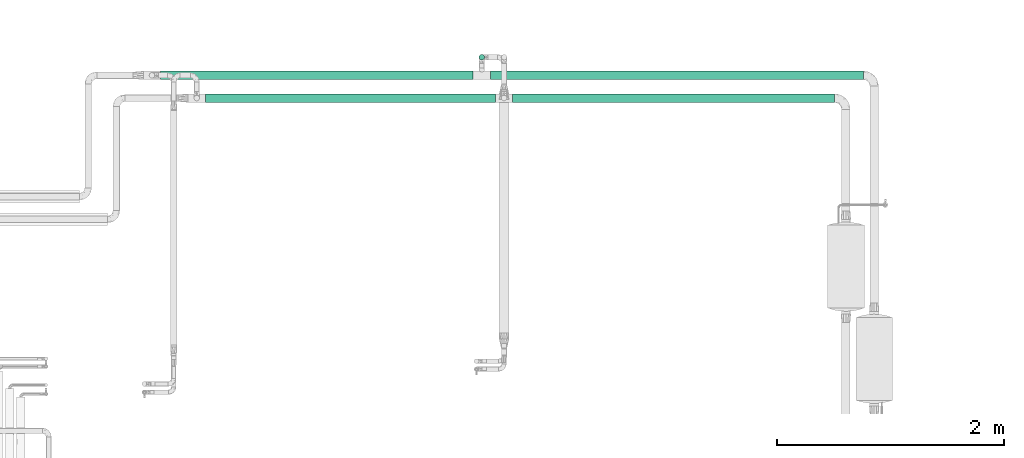
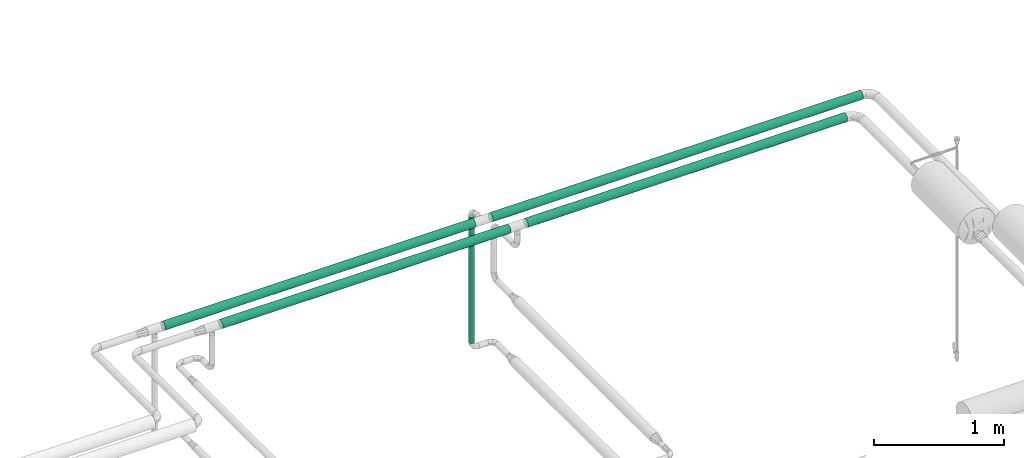
# One storey, part 529 of 827: 5 flow segments.
"""IFC2X3 building model written with IfcOpenShell, lengths in millimetres."""

import ifcopenshell
import ifcopenshell.guid

model = None  # the IFC model being written
_history = None  # IfcOwnerHistory: only IFC2X3 demands one
_inside = {}  # id of a spatial element -> (the spatial element, [elements in it])
_under = {}  # id of a project, library or spatial element -> (it, [spatial elements below it])
_declared = {}  # id of a project -> (the project, [libraries it declares])
_typed = {}  # id of a type object -> (the type object, [elements of that type])
_made_of = {}  # id of a material, layer set ... -> (it, [elements and type objects made of it])


def new_model(schema):
    """Start an empty IFC model of exactly this schema.

    Asked for "IFC4X3", IfcOpenShell would pick the latest addendum, in which some entities
    have other attributes; the version numbers below select the first issue.
    IFC2X3 requires an IfcOwnerHistory on every rooted entity: one is made here for all.
    """
    global model, _history
    if schema == "IFC4X3":
        model = ifcopenshell.file(schema_version=(4, 3, 0, 0))
    else:
        model = ifcopenshell.file(schema=schema)
    _inside.clear()
    _under.clear()
    _declared.clear()
    _typed.clear()
    _made_of.clear()
    _history = None
    if model.schema == "IFC2X3":
        org = make("IfcOrganization", Name="unknown")
        user = make(
            "IfcPersonAndOrganization",
            ThePerson=make("IfcPerson", FamilyName="unknown"),
            TheOrganization=org,
        )
        app = make(
            "IfcApplication",
            ApplicationDeveloper=org,
            Version="unknown",
            ApplicationFullName="unknown",
            ApplicationIdentifier="unknown",
        )
        _history = make(
            "IfcOwnerHistory",
            OwningUser=user,
            OwningApplication=app,
            ChangeAction="ADDED",
            CreationDate=0,
        )
    return model


def make(cls, **values):
    """One entity of the class cls with the attributes given. An attribute that is None is left unset."""
    return model.create_entity(
        cls, **{name: value for name, value in values.items() if value is not None}
    )


def entity(cls, *values):
    """Any entity or typed value of the class cls, its attributes in the order of the schema. None: left unset."""
    e = model.create_entity(cls)
    for i, value in enumerate(values):
        if value is not None:
            e[i] = value
    return e


def rooted(cls, **values):
    """An entity with a GlobalId (a new one), such as an element, a storey or a relation."""
    return make(cls, GlobalId=ifcopenshell.guid.new(), OwnerHistory=_history, **values)


def si_unit(unit_type, name, prefix=None):
    """IfcSIUnit, for example si_unit("LENGTHUNIT", "METRE", prefix="MILLI")."""
    return make("IfcSIUnit", UnitType=unit_type, Prefix=prefix, Name=name)


def converted_unit(unit_type, name, factor, base, dimensions=None, offset=None):
    """IfcConversionBasedUnit, such as the inch: factor (a typed value) times the base unit."""
    return make(
        "IfcConversionBasedUnit"
        if offset is None
        else "IfcConversionBasedUnitWithOffset",
        ConversionOffset=offset,
        Dimensions=None
        if dimensions is None
        else entity("IfcDimensionalExponents", *dimensions),
        UnitType=unit_type,
        Name=name,
        ConversionFactor=make(
            "IfcMeasureWithUnit", ValueComponent=factor, UnitComponent=base
        ),
    )


def derived_unit(unit_type, elements):
    """IfcDerivedUnit: a product of units, each with its exponent."""
    return make(
        "IfcDerivedUnit",
        Elements=[
            make("IfcDerivedUnitElement", Unit=unit, Exponent=power)
            for unit, power in elements
        ],
        UnitType=unit_type,
    )


def assignment(units):
    """IfcUnitAssignment: the units of a project."""
    return None if units is None else make("IfcUnitAssignment", Units=units)


def point(xyz):
    """IfcCartesianPoint."""
    return None if xyz is None else make("IfcCartesianPoint", Coordinates=xyz)


def direction(xyz):
    """IfcDirection."""
    return None if xyz is None else make("IfcDirection", DirectionRatios=xyz)


def frame(location, z_axis=None, x_axis=None):
    """IfcAxis2Placement3D, a coordinate frame: its origin and axes. An axis left out is left unset."""
    return make(
        "IfcAxis2Placement3D",
        Location=point(location),
        Axis=direction(z_axis),
        RefDirection=direction(x_axis),
    )


def frame_2d(location, x_axis=None):
    """IfcAxis2Placement2D, a coordinate frame in the plane: its origin and x axis."""
    return make(
        "IfcAxis2Placement2D", Location=point(location), RefDirection=direction(x_axis)
    )


def origin():
    """The frame at (0, 0, 0) with its axes left unset."""
    return frame((0.0, 0.0, 0.0))


def origin_2d_with_axis():
    """The frame at (0, 0) in the plane with the x axis (1, 0) written out."""
    return frame_2d((0.0, 0.0), x_axis=(1.0, 0.0))


def place(relative_to, where):
    """IfcLocalPlacement: puts the frame where relative to a parent placement (None: the world)."""
    return make(
        "IfcLocalPlacement", PlacementRelTo=relative_to, RelativePlacement=where
    )


def context(
    kind, dimensions, precision=None, world=None, true_north=None, identifier=None
):
    """IfcGeometricRepresentationContext, for example the 3D "Model" context."""
    return make(
        "IfcGeometricRepresentationContext",
        ContextIdentifier=identifier,
        ContextType=kind,
        CoordinateSpaceDimension=dimensions,
        Precision=precision,
        WorldCoordinateSystem=world,
        TrueNorth=true_north,
    )


def subcontext(parent, identifier, kind, view, scale=None):
    """IfcGeometricRepresentationSubContext, for example "Body" below "Model"."""
    return make(
        "IfcGeometricRepresentationSubContext",
        ContextIdentifier=identifier,
        ContextType=kind,
        ParentContext=parent,
        TargetScale=scale,
        TargetView=view,
    )


def project(units=None, contexts=None):
    """IfcProject with its units and contexts."""
    return rooted(
        "IfcProject",
        Name="project",
        RepresentationContexts=contexts,
        UnitsInContext=assignment(units),
    )


def spatial(cls, under=None, at=None, **own):
    """A site, building, storey or space (cls), placed at a placement, below another one or the project."""
    s = rooted(cls, ObjectPlacement=at, **own)
    if under is not None:
        _under.setdefault(under.id(), (under, []))[1].append(s)
    return s


def profile(cls, at=None, kind="AREA", **sizes):
    """A parametric profile (cls). Its sizes go by their IFC names, for example OverallWidth=200.0."""
    return make(cls, ProfileType=kind, Position=at, **sizes)


def circle(**sizes):
    """IfcCircleProfileDef."""
    return profile("IfcCircleProfileDef", **sizes)


def extrude(swept, where, along, depth):
    """IfcExtrudedAreaSolid: the profile swept, set in the frame where, extruded along a direction by depth."""
    return make(
        "IfcExtrudedAreaSolid",
        SweptArea=swept,
        Position=where,
        ExtrudedDirection=direction(along),
        Depth=depth,
    )


def shape(context_of_items, identifier, shape_type, items):
    """IfcShapeRepresentation: the items that make up one representation, for example the "Body"."""
    return make(
        "IfcShapeRepresentation",
        ContextOfItems=context_of_items,
        RepresentationIdentifier=identifier,
        RepresentationType=shape_type,
        Items=items,
    )


def made_of(thing, what):
    """Note that an element or type object is made of a material, layer set ...; save() writes the relation."""
    if what is not None:
        _made_of.setdefault(what.id(), (what, []))[1].append(thing)
    return thing


def type_object(cls, material=None, **own):
    """A type object (cls), such as IfcWallType, which elements share."""
    return made_of(rooted(cls, **own), material)


def element(
    cls,
    number,
    at=None,
    inside=None,
    cuts=None,
    type_object=None,
    material=None,
    context=None,
    identifier="Body",
    shape_type=None,
    held_by="IfcProductDefinitionShape",
    body=None,
    shapes=None,
    **own,
):
    """One element of the class cls, such as IfcWall. Its Tag is "e" and its number.

    at: its placement. inside: the storey or other place that contains it. cuts: it is an
    opening in that element (IfcRelVoidsElement). A single representation is given by context,
    identifier, shape_type and body (its items); several are given by shapes. held_by: the class
    of the entity that holds the representations. save() writes the other relations.
    """
    e = rooted(cls, Tag="e%d" % number, ObjectPlacement=at, **own)
    if body is not None:
        shapes = [shape(context, identifier, shape_type, body)]
    if shapes is not None:
        e.Representation = make(held_by, Representations=shapes)
    if inside is not None:
        _inside.setdefault(inside.id(), (inside, []))[1].append(e)
    if cuts is not None:
        rooted(
            "IfcRelVoidsElement", RelatingBuildingElement=cuts, RelatedOpeningElement=e
        )
    if type_object is not None:
        _typed.setdefault(type_object.id(), (type_object, []))[1].append(e)
    return made_of(e, material)


def aggregate(whole, parts):
    """IfcRelAggregates: a whole, such as a stair, and the parts it consists of."""
    return rooted("IfcRelAggregates", RelatingObject=whole, RelatedObjects=parts)


def save(model, path):
    """Write the relations noted so far, then the file.

    IfcRelAggregates (storeys below a building ...), IfcRelContainedInSpatialStructure (elements
    in a storey), IfcRelDefinesByType, IfcRelAssociatesMaterial and IfcRelDeclares: one each for
    every whole, place, type object, material and project.
    """
    for whole, parts in _under.values():
        aggregate(whole, parts)
    for where, things in _inside.values():
        rooted(
            "IfcRelContainedInSpatialStructure",
            RelatedElements=things,
            RelatingStructure=where,
        )
    for kind, things in _typed.values():
        rooted("IfcRelDefinesByType", RelatedObjects=things, RelatingType=kind)
    for what, things in _made_of.values():
        rooted("IfcRelAssociatesMaterial", RelatedObjects=things, RelatingMaterial=what)
    for by, libraries in _declared.values():
        rooted("IfcRelDeclares", RelatingContext=by, RelatedDefinitions=libraries)
    model.write(path)


model = new_model("IFC2X3")

# Units and contexts
model_context = context("Model", 3, precision=0.01, world=origin(), true_north=direction((6.12303176911189e-17, 1.0)))
body_context = subcontext(model_context, "Body", "Model", "MODEL_VIEW")
ifc_project = project(units=[si_unit("LENGTHUNIT", "METRE", prefix="MILLI"), si_unit("AREAUNIT", "SQUARE_METRE"), si_unit("VOLUMEUNIT", "CUBIC_METRE"), converted_unit("PLANEANGLEUNIT", "DEGREE", entity("IfcRatioMeasure", 0.0174532925199433), si_unit("PLANEANGLEUNIT", "RADIAN"), dimensions=[0, 0, 0, 0, 0, 0, 0]), si_unit("MASSUNIT", "GRAM", prefix="KILO"), derived_unit("MASSDENSITYUNIT", [(si_unit("MASSUNIT", "GRAM", prefix="KILO"), 1), (si_unit("LENGTHUNIT", "METRE"), -3)]), derived_unit("MOMENTOFINERTIAUNIT", [(si_unit("LENGTHUNIT", "METRE"), 4)]), si_unit("TIMEUNIT", "SECOND"), si_unit("FREQUENCYUNIT", "HERTZ"), si_unit("THERMODYNAMICTEMPERATUREUNIT", "DEGREE_CELSIUS"), derived_unit("THERMALTRANSMITTANCEUNIT", [(si_unit("MASSUNIT", "GRAM", prefix="KILO"), 1), (si_unit("THERMODYNAMICTEMPERATUREUNIT", "KELVIN"), -1), (si_unit("TIMEUNIT", "SECOND"), -3)]), derived_unit("VOLUMETRICFLOWRATEUNIT", [(si_unit("LENGTHUNIT", "METRE"), 3), (si_unit("TIMEUNIT", "SECOND"), -1)]), derived_unit("MASSFLOWRATEUNIT", [(si_unit("MASSUNIT", "GRAM", prefix="KILO"), 1), (si_unit("TIMEUNIT", "SECOND"), -1)]), derived_unit("ROTATIONALFREQUENCYUNIT", [(si_unit("TIMEUNIT", "SECOND"), -1)]), si_unit("ELECTRICCURRENTUNIT", "AMPERE"), si_unit("ELECTRICVOLTAGEUNIT", "VOLT"), si_unit("POWERUNIT", "WATT"), si_unit("FORCEUNIT", "NEWTON", prefix="KILO"), si_unit("ILLUMINANCEUNIT", "LUX"), si_unit("LUMINOUSFLUXUNIT", "LUMEN"), si_unit("LUMINOUSINTENSITYUNIT", "CANDELA"), derived_unit("USERDEFINED", [(si_unit("MASSUNIT", "GRAM", prefix="KILO"), -1), (si_unit("LENGTHUNIT", "METRE"), -2), (si_unit("TIMEUNIT", "SECOND"), 3), (si_unit("LUMINOUSFLUXUNIT", "LUMEN"), 1)]), derived_unit("LINEARVELOCITYUNIT", [(si_unit("LENGTHUNIT", "METRE"), 1), (si_unit("TIMEUNIT", "SECOND"), -1)]), si_unit("PRESSUREUNIT", "PASCAL"), derived_unit("USERDEFINED", [(si_unit("LENGTHUNIT", "METRE"), -2), (si_unit("MASSUNIT", "GRAM", prefix="KILO"), 1), (si_unit("TIMEUNIT", "SECOND"), -2)]), derived_unit("LINEARFORCEUNIT", [(si_unit("MASSUNIT", "GRAM", prefix="KILO"), 1), (si_unit("LENGTHUNIT", "METRE"), 1), (si_unit("TIMEUNIT", "SECOND"), -2), (si_unit("LENGTHUNIT", "METRE"), -1)]), derived_unit("PLANARFORCEUNIT", [(si_unit("MASSUNIT", "GRAM", prefix="KILO"), 1), (si_unit("LENGTHUNIT", "METRE"), 1), (si_unit("TIMEUNIT", "SECOND"), -2), (si_unit("LENGTHUNIT", "METRE"), -2)])], contexts=[model_context])

# Site, building, storey
site_placement = place(None, origin())
site = spatial("IfcSite", under=ifc_project, at=site_placement, CompositionType="ELEMENT")
building_placement = place(site_placement, origin())
building = spatial("IfcBuilding", under=site, at=building_placement, CompositionType="ELEMENT")
storey_placement = place(building_placement, frame((0.0, 0.0, 28200.0)))
storey = spatial("IfcBuildingStorey", under=building, at=storey_placement, Name="08", CompositionType="ELEMENT", Elevation=28200.0)

# Flow segments
pipe_segment_type_1 = type_object("IfcPipeSegmentType", PredefinedType="NOTDEFINED")
flow_segment_1_placement = place(storey_placement, frame((23012.46, 18840.4, 2960.4)))
element("IfcFlowSegment", 1, at=flow_segment_1_placement, inside=storey, type_object=pipe_segment_type_1, context=body_context, shape_type="SweptSolid", body=[
    extrude(circle(Radius=38.0, at=origin_2d_with_axis()), frame((0.0, 39.6, 39.6), z_axis=(1.0, 0.0, 0.0), x_axis=(0.0, -1.0, 0.0)), (0.0, 0.0, 1.0), 2831.71587502247),
])
flow_segment_2_placement = place(storey_placement, frame((22816.03, 19040.4, 2960.4)))
element("IfcFlowSegment", 2, at=flow_segment_2_placement, inside=storey, type_object=pipe_segment_type_1, context=body_context, shape_type="SweptSolid", body=[
    extrude(circle(Radius=38.0, at=origin_2d_with_axis()), frame((0.0, 39.6, 39.6), z_axis=(1.0, 0.0, 0.0), x_axis=(0.0, -1.0, 0.0)), (0.0, 0.0, 1.0), 3282.87594554333),
])
flow_segment_3_placement = place(storey_placement, frame((20307.46, 18840.4, 2960.4)))
element("IfcFlowSegment", 3, at=flow_segment_3_placement, inside=storey, type_object=pipe_segment_type_1, context=body_context, shape_type="SweptSolid", body=[
    extrude(circle(Radius=38.0, at=origin_2d_with_axis()), frame((0.0, 39.6, 39.6), z_axis=(1.0, 0.0, 0.0), x_axis=(0.0, -1.0, 0.0)), (0.0, 0.0, 1.0), 2553.0),
])
flow_segment_4_placement = place(storey_placement, frame((19913.21, 19040.4, 2960.4)))
element("IfcFlowSegment", 4, at=flow_segment_4_placement, inside=storey, type_object=pipe_segment_type_1, context=body_context, shape_type="SweptSolid", body=[
    extrude(circle(Radius=38.0, at=origin_2d_with_axis()), frame((0.0, 39.6, 39.6), z_axis=(1.0, 0.0, 0.0), x_axis=(0.0, -1.0, 0.0)), (0.0, 0.0, 1.0), 2750.82042068439),
])
pipe_segment_type_2 = type_object("IfcPipeSegmentType", PredefinedType="NOTDEFINED")
flow_segment_5_placement = place(storey_placement, frame((22714.44, 19214.7, 1764.06)))
element("IfcFlowSegment", 5, at=flow_segment_5_placement, inside=storey, type_object=pipe_segment_type_2, context=body_context, shape_type="SweptSolid", body=[
    extrude(circle(Radius=24.0, at=origin_2d_with_axis()), frame((25.6, 25.6, 0.0), z_axis=(0.0, 0.0, 1.0), x_axis=(-1.0, 0.0, 0.0)), (0.0, 0.0, 1.0), 1178.94077606713),
])

save(model, "model.ifc")
